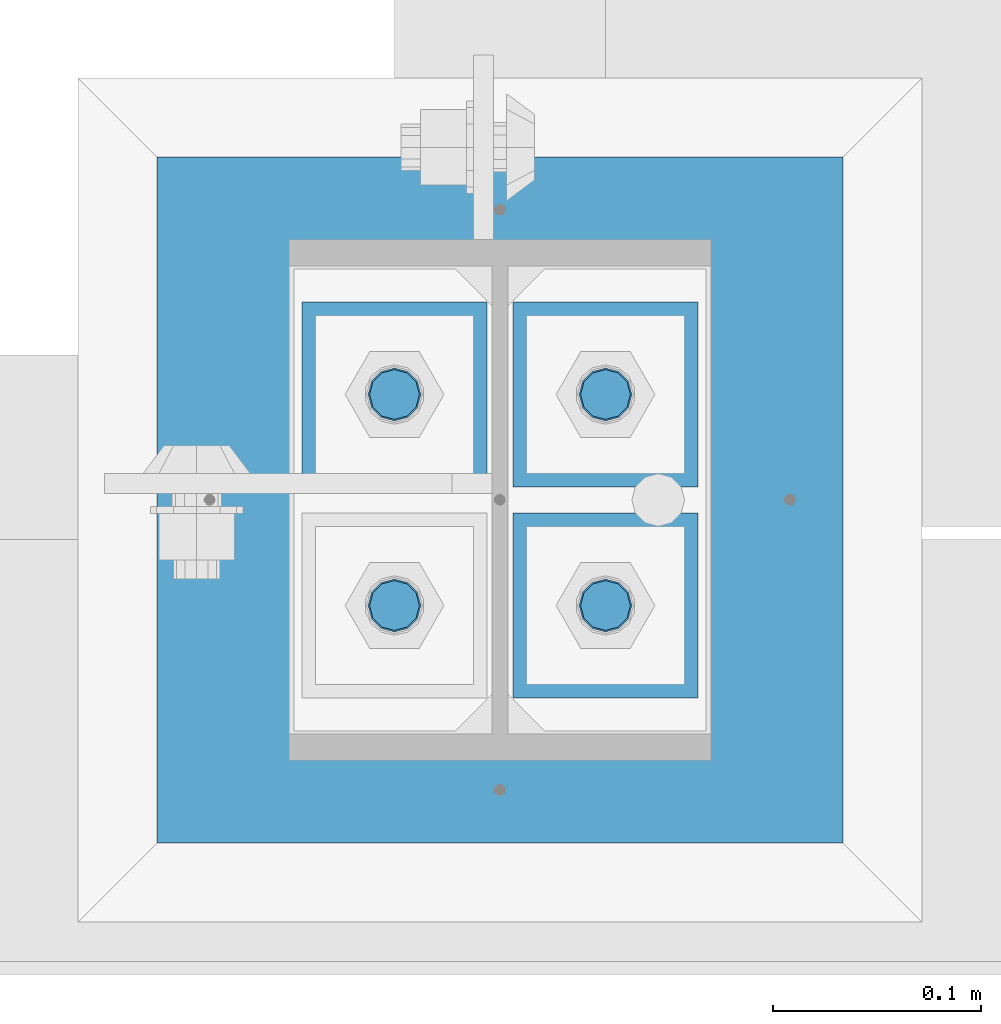
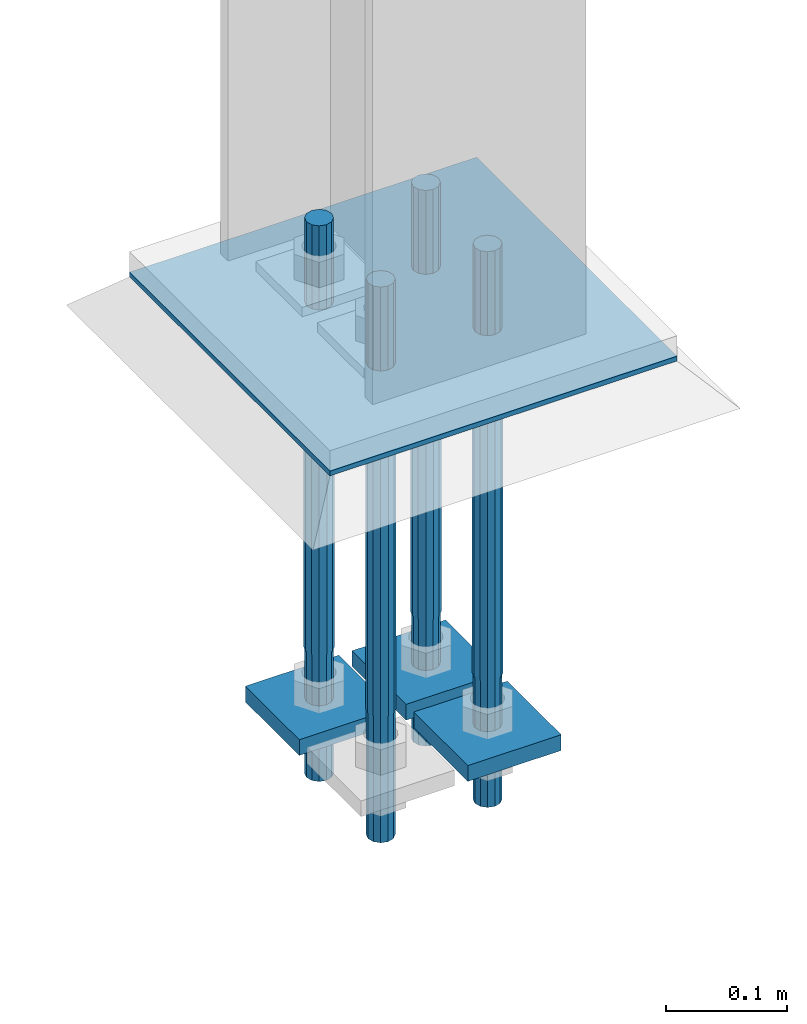
# One storey, part 2554 of 3843: 8 beams, 1 element without a shape of its own.
"""IFC2X3 building model written with IfcOpenShell, lengths in millimetres."""

from ifc_helpers import new_model, si_unit, frame, origin_with_axes, place, context, subcontext, project, spatial, faceted_brep, material, type_object, element, aggregate, save


model = new_model("IFC2X3")

# Units and contexts
model_context = context("Model", 3, precision=1e-05, world=origin_with_axes())
body_context = subcontext(model_context, "Body", "Model", "MODEL_VIEW")
ifc_project = project(units=[si_unit("LENGTHUNIT", "METRE", prefix="MILLI"), si_unit("AREAUNIT", "SQUARE_METRE"), si_unit("VOLUMEUNIT", "CUBIC_METRE"), si_unit("MASSUNIT", "GRAM", prefix="KILO"), si_unit("TIMEUNIT", "SECOND"), si_unit("PLANEANGLEUNIT", "RADIAN"), si_unit("SOLIDANGLEUNIT", "STERADIAN"), si_unit("THERMODYNAMICTEMPERATUREUNIT", "DEGREE_CELSIUS"), si_unit("LUMINOUSINTENSITYUNIT", "LUMEN")], contexts=[model_context])

# Site, building, storey
site_placement = place(None, origin_with_axes())
site = spatial("IfcSite", under=ifc_project, at=site_placement, CompositionType="ELEMENT")
building_placement = place(site_placement, origin_with_axes())
building = spatial("IfcBuilding", under=site, at=building_placement, Name="Undefined", CompositionType="ELEMENT")
storey_placement = place(building_placement, origin_with_axes())
storey = spatial("IfcBuildingStorey", under=building, at=storey_placement, Name="Undefined", CompositionType="ELEMENT", Elevation=0.0)

# Assembly, beams
assembly_placement = place(storey_placement, origin_with_axes())
assembly = element("IfcElementAssembly", 1, at=assembly_placement, inside=storey, Name="TEMPLATE", AssemblyPlace="NOTDEFINED", PredefinedType="RIGID_FRAME")
ifc_material_1 = material(Name="Undefined/F1554-GR.55")
beam_type_1 = type_object("IfcBeamType", PredefinedType="NOTDEFINED")
beam_1_placement = place(assembly_placement, frame((85598.0, 10985.5, 30022.8), z_axis=(0.0, -1.0, 0.0), x_axis=(0.0, 0.0, -1.0)))
beam_1 = element("IfcBeam", 2, at=beam_1_placement, type_object=beam_type_1, material=ifc_material_1, Name="ANCHOR_ROD", context=body_context, shape_type="Brep", body=[
    faceted_brep([(-127.0, -10.3923048454162, 6.0), (-127.0, -6.0, 10.3923048454126), (-127.0, 0.0, 12.0), (-127.0, 6.0, 10.3923048454126), (-127.0, 10.3923048454162, 6.0), (-127.0, 12.0, 0.0), (-127.0, 10.3923048454162, -6.0), (-127.0, 6.0, -10.3923048454126), (-127.0, 0.0, -12.0), (-127.0, -6.0, -10.3923048454126), (-127.0, -10.3923048454162, -6.0), (-127.0, -12.0, 0.0), (0.0, 12.0, 0.0), (0.0, 10.3923048454162, -6.0), (0.0, 6.0, -10.3923048454126), (0.0, 0.0, -12.0), (0.0, -6.0, -10.3923048454126), (0.0, -10.3923048454162, -6.0), (0.0, -12.0, 0.0), (0.0, -10.3923048454162, 6.0), (0.0, -6.0, 10.3923048454126), (0.0, 0.0, 12.0), (0.0, 6.0, 10.3923048454126), (0.0, 10.3923048454162, 6.0), (0.0, -10.9985226280696, 6.34999999999854), (0.0, -6.35000000000582, 10.9985226280623), (0.0, 0.0, 12.6999999999971), (0.0, 6.35000000000582, 10.9985226280623), (0.0, 10.9985226280696, 6.34999999999854), (0.0, 12.6999999999971, 0.0), (0.0, 10.9985226280696, -6.34999999999854), (0.0, 6.35000000000582, -10.9985226280623), (0.0, 0.0, -12.6999999999971), (0.0, -6.35000000000582, -10.9985226280623), (0.0, -10.9985226280696, -6.34999999999854), (0.0, -12.6999999999971, 0.0), (304.799999999999, -12.6999999999971, 0.0), (304.799999999999, -10.9985226280623, 6.35000000000036), (304.799999999999, -6.34999999999854, 10.9985226280623), (304.799999999999, 0.0, 12.7000000000007), (304.799999999999, 6.34999999999854, 10.9985226280623), (304.799999999999, 10.9985226280623, 6.35000000000036), (304.799999999999, 12.6999999999971, 0.0), (304.799999999999, 10.9985226280623, -6.35000000000036), (304.799999999999, 6.34999999999854, -10.9985226280623), (304.799999999999, 0.0, -12.7000000000007), (304.799999999999, -6.34999999999854, -10.9985226280623), (304.799999999999, -10.9985226280623, -6.35000000000036), (304.799999999999, -6.0, 10.3923048454126), (304.799999999999, 0.0, 12.0), (304.799999999999, 6.0, 10.3923048454126), (304.799999999999, 10.3923048454162, 6.0), (304.799999999999, 12.0, 0.0), (304.799999999999, 10.3923048454162, -6.0), (304.799999999999, 6.0, -10.3923048454126), (304.799999999999, 0.0, -12.0), (304.799999999999, -6.0, -10.3923048454126), (304.799999999999, -10.3923048454162, -6.0), (304.799999999999, -12.0, 0.0), (304.799999999999, -10.3923048454162, 6.0), (431.799999999999, -6.0, -10.3923048454126), (431.799999999999, 0.0, -12.0), (431.799999999999, 6.0, -10.3923048454126), (431.799999999999, 10.3923048454162, -6.0), (431.799999999999, 12.0, 0.0), (431.799999999999, 10.3923048454162, 6.0), (431.799999999999, 6.0, 10.3923048454126), (431.799999999999, 0.0, 12.0), (431.799999999999, -6.0, 10.3923048454126), (431.799999999999, -10.3923048454162, 6.0), (431.799999999999, -12.0, 0.0), (431.799999999999, -10.3923048454162, -6.0)], [[[0, 1, 2, 3, 4, 5, 6, 7, 8, 9, 10, 11]], [[6, 5, 12, 13]], [[7, 6, 13, 14]], [[8, 7, 14, 15]], [[9, 8, 15, 16]], [[10, 9, 16, 17]], [[11, 10, 17, 18]], [[0, 11, 18, 19]], [[1, 0, 19, 20]], [[2, 1, 20, 21]], [[3, 2, 21, 22]], [[4, 3, 22, 23]], [[5, 4, 23, 12]], [[24, 25, 26, 27, 28, 29, 30, 31, 32, 33, 34, 35], [22, 21, 20, 19, 18, 17, 16, 15, 14, 13, 12, 23]], [[24, 35, 36, 37]], [[25, 24, 37, 38]], [[26, 25, 38, 39]], [[27, 26, 39, 40]], [[28, 27, 40, 41]], [[29, 28, 41, 42]], [[30, 29, 42, 43]], [[31, 30, 43, 44]], [[32, 31, 44, 45]], [[33, 32, 45, 46]], [[34, 33, 46, 47]], [[35, 34, 47, 36]], [[46, 45, 44, 43, 42, 41, 40, 39, 38, 37, 36, 47], [48, 49, 50, 51, 52, 53, 54, 55, 56, 57, 58, 59]], [[60, 61, 62, 63, 64, 65, 66, 67, 68, 69, 70, 71]], [[68, 67, 49, 48]], [[69, 68, 48, 59]], [[70, 69, 59, 58]], [[71, 70, 58, 57]], [[60, 71, 57, 56]], [[61, 60, 56, 55]], [[62, 61, 55, 54]], [[63, 62, 54, 53]], [[64, 63, 53, 52]], [[65, 64, 52, 51]], [[66, 65, 51, 50]], [[67, 66, 50, 49]]]),
])
beam_2_placement = place(assembly_placement, frame((85699.6, 10985.5, 30022.8), z_axis=(0.0, 1.0, 0.0), x_axis=(0.0, 0.0, -1.0)))
beam_2 = element("IfcBeam", 3, at=beam_2_placement, type_object=beam_type_1, material=ifc_material_1, Name="ANCHOR_ROD", context=body_context, shape_type="Brep", body=[
    faceted_brep([(-127.0, -10.3923048454162, 6.0), (-127.0, -6.0, 10.3923048454126), (-127.0, 0.0, 12.0), (-127.0, 6.0, 10.3923048454126), (-127.0, 10.3923048454162, 6.0), (-127.0, 12.0, 0.0), (-127.0, 10.3923048454162, -6.0), (-127.0, 6.0, -10.3923048454126), (-127.0, 0.0, -12.0), (-127.0, -6.0, -10.3923048454126), (-127.0, -10.3923048454162, -6.0), (-127.0, -12.0, 0.0), (0.0, 12.0, 0.0), (0.0, 10.3923048454162, -6.0), (0.0, 6.0, -10.3923048454126), (0.0, 0.0, -12.0), (0.0, -6.0, -10.3923048454126), (0.0, -10.3923048454162, -6.0), (0.0, -12.0, 0.0), (0.0, -10.3923048454162, 6.0), (0.0, -6.0, 10.3923048454126), (0.0, 0.0, 12.0), (0.0, 6.0, 10.3923048454126), (0.0, 10.3923048454162, 6.0), (0.0, -10.9985226280696, 6.34999999999854), (0.0, -6.35000000000582, 10.9985226280623), (0.0, 0.0, 12.6999999999971), (0.0, 6.35000000000582, 10.9985226280623), (0.0, 10.9985226280696, 6.34999999999854), (0.0, 12.6999999999971, 0.0), (0.0, 10.9985226280696, -6.34999999999854), (0.0, 6.35000000000582, -10.9985226280623), (0.0, 0.0, -12.6999999999971), (0.0, -6.35000000000582, -10.9985226280623), (0.0, -10.9985226280696, -6.34999999999854), (0.0, -12.6999999999971, 0.0), (304.799999999999, -12.6999999999971, 0.0), (304.799999999999, -10.9985226280623, 6.35000000000036), (304.799999999999, -6.34999999999854, 10.9985226280623), (304.799999999999, 0.0, 12.7000000000007), (304.799999999999, 6.34999999999854, 10.9985226280623), (304.799999999999, 10.9985226280623, 6.35000000000036), (304.799999999999, 12.6999999999971, 0.0), (304.799999999999, 10.9985226280623, -6.35000000000036), (304.799999999999, 6.34999999999854, -10.9985226280623), (304.799999999999, 0.0, -12.7000000000007), (304.799999999999, -6.34999999999854, -10.9985226280623), (304.799999999999, -10.9985226280623, -6.35000000000036), (304.799999999999, -6.0, 10.3923048454126), (304.799999999999, 0.0, 12.0), (304.799999999999, 6.0, 10.3923048454126), (304.799999999999, 10.3923048454162, 6.0), (304.799999999999, 12.0, 0.0), (304.799999999999, 10.3923048454162, -6.0), (304.799999999999, 6.0, -10.3923048454126), (304.799999999999, 0.0, -12.0), (304.799999999999, -6.0, -10.3923048454126), (304.799999999999, -10.3923048454162, -6.0), (304.799999999999, -12.0, 0.0), (304.799999999999, -10.3923048454162, 6.0), (431.799999999999, -6.0, -10.3923048454126), (431.799999999999, 0.0, -12.0), (431.799999999999, 6.0, -10.3923048454126), (431.799999999999, 10.3923048454162, -6.0), (431.799999999999, 12.0, 0.0), (431.799999999999, 10.3923048454162, 6.0), (431.799999999999, 6.0, 10.3923048454126), (431.799999999999, 0.0, 12.0), (431.799999999999, -6.0, 10.3923048454126), (431.799999999999, -10.3923048454162, 6.0), (431.799999999999, -12.0, 0.0), (431.799999999999, -10.3923048454162, -6.0)], [[[0, 1, 2, 3, 4, 5, 6, 7, 8, 9, 10, 11]], [[6, 5, 12, 13]], [[7, 6, 13, 14]], [[8, 7, 14, 15]], [[9, 8, 15, 16]], [[10, 9, 16, 17]], [[11, 10, 17, 18]], [[0, 11, 18, 19]], [[1, 0, 19, 20]], [[2, 1, 20, 21]], [[3, 2, 21, 22]], [[4, 3, 22, 23]], [[5, 4, 23, 12]], [[24, 25, 26, 27, 28, 29, 30, 31, 32, 33, 34, 35], [22, 21, 20, 19, 18, 17, 16, 15, 14, 13, 12, 23]], [[24, 35, 36, 37]], [[25, 24, 37, 38]], [[26, 25, 38, 39]], [[27, 26, 39, 40]], [[28, 27, 40, 41]], [[29, 28, 41, 42]], [[30, 29, 42, 43]], [[31, 30, 43, 44]], [[32, 31, 44, 45]], [[33, 32, 45, 46]], [[34, 33, 46, 47]], [[35, 34, 47, 36]], [[46, 45, 44, 43, 42, 41, 40, 39, 38, 37, 36, 47], [48, 49, 50, 51, 52, 53, 54, 55, 56, 57, 58, 59]], [[60, 61, 62, 63, 64, 65, 66, 67, 68, 69, 70, 71]], [[68, 67, 49, 48]], [[69, 68, 48, 59]], [[70, 69, 59, 58]], [[71, 70, 58, 57]], [[60, 71, 57, 56]], [[61, 60, 56, 55]], [[62, 61, 55, 54]], [[63, 62, 54, 53]], [[64, 63, 53, 52]], [[65, 64, 52, 51]], [[66, 65, 51, 50]], [[67, 66, 50, 49]]]),
])
beam_3_placement = place(assembly_placement, frame((85598.0, 11087.1, 30022.8), z_axis=(0.0, -1.0, 0.0), x_axis=(0.0, 0.0, -1.0)))
beam_3 = element("IfcBeam", 4, at=beam_3_placement, type_object=beam_type_1, material=ifc_material_1, Name="ANCHOR_ROD", context=body_context, shape_type="Brep", body=[
    faceted_brep([(-127.0, -10.3923048454162, 6.0), (-127.0, -6.0, 10.3923048454126), (-127.0, 0.0, 12.0), (-127.0, 6.0, 10.3923048454126), (-127.0, 10.3923048454162, 6.0), (-127.0, 12.0, 0.0), (-127.0, 10.3923048454162, -6.0), (-127.0, 6.0, -10.3923048454126), (-127.0, 0.0, -12.0), (-127.0, -6.0, -10.3923048454126), (-127.0, -10.3923048454162, -6.0), (-127.0, -12.0, 0.0), (0.0, 12.0, 0.0), (0.0, 10.3923048454162, -6.0), (0.0, 6.0, -10.3923048454126), (0.0, 0.0, -12.0), (0.0, -6.0, -10.3923048454126), (0.0, -10.3923048454162, -6.0), (0.0, -12.0, 0.0), (0.0, -10.3923048454162, 6.0), (0.0, -6.0, 10.3923048454126), (0.0, 0.0, 12.0), (0.0, 6.0, 10.3923048454126), (0.0, 10.3923048454162, 6.0), (0.0, -10.9985226280696, 6.34999999999854), (0.0, -6.35000000000582, 10.9985226280623), (0.0, 0.0, 12.6999999999971), (0.0, 6.35000000000582, 10.9985226280623), (0.0, 10.9985226280696, 6.34999999999854), (0.0, 12.6999999999971, 0.0), (0.0, 10.9985226280696, -6.34999999999854), (0.0, 6.35000000000582, -10.9985226280623), (0.0, 0.0, -12.6999999999971), (0.0, -6.35000000000582, -10.9985226280623), (0.0, -10.9985226280696, -6.34999999999854), (0.0, -12.6999999999971, 0.0), (304.799999999999, -12.6999999999971, 0.0), (304.799999999999, -10.9985226280623, 6.35000000000036), (304.799999999999, -6.34999999999854, 10.9985226280623), (304.799999999999, 0.0, 12.7000000000007), (304.799999999999, 6.34999999999854, 10.9985226280623), (304.799999999999, 10.9985226280623, 6.35000000000036), (304.799999999999, 12.6999999999971, 0.0), (304.799999999999, 10.9985226280623, -6.35000000000036), (304.799999999999, 6.34999999999854, -10.9985226280623), (304.799999999999, 0.0, -12.7000000000007), (304.799999999999, -6.34999999999854, -10.9985226280623), (304.799999999999, -10.9985226280623, -6.35000000000036), (304.799999999999, -6.0, 10.3923048454126), (304.799999999999, 0.0, 12.0), (304.799999999999, 6.0, 10.3923048454126), (304.799999999999, 10.3923048454162, 6.0), (304.799999999999, 12.0, 0.0), (304.799999999999, 10.3923048454162, -6.0), (304.799999999999, 6.0, -10.3923048454126), (304.799999999999, 0.0, -12.0), (304.799999999999, -6.0, -10.3923048454126), (304.799999999999, -10.3923048454162, -6.0), (304.799999999999, -12.0, 0.0), (304.799999999999, -10.3923048454162, 6.0), (431.799999999999, -6.0, -10.3923048454126), (431.799999999999, 0.0, -12.0), (431.799999999999, 6.0, -10.3923048454126), (431.799999999999, 10.3923048454162, -6.0), (431.799999999999, 12.0, 0.0), (431.799999999999, 10.3923048454162, 6.0), (431.799999999999, 6.0, 10.3923048454126), (431.799999999999, 0.0, 12.0), (431.799999999999, -6.0, 10.3923048454126), (431.799999999999, -10.3923048454162, 6.0), (431.799999999999, -12.0, 0.0), (431.799999999999, -10.3923048454162, -6.0)], [[[0, 1, 2, 3, 4, 5, 6, 7, 8, 9, 10, 11]], [[6, 5, 12, 13]], [[7, 6, 13, 14]], [[8, 7, 14, 15]], [[9, 8, 15, 16]], [[10, 9, 16, 17]], [[11, 10, 17, 18]], [[0, 11, 18, 19]], [[1, 0, 19, 20]], [[2, 1, 20, 21]], [[3, 2, 21, 22]], [[4, 3, 22, 23]], [[5, 4, 23, 12]], [[24, 25, 26, 27, 28, 29, 30, 31, 32, 33, 34, 35], [22, 21, 20, 19, 18, 17, 16, 15, 14, 13, 12, 23]], [[24, 35, 36, 37]], [[25, 24, 37, 38]], [[26, 25, 38, 39]], [[27, 26, 39, 40]], [[28, 27, 40, 41]], [[29, 28, 41, 42]], [[30, 29, 42, 43]], [[31, 30, 43, 44]], [[32, 31, 44, 45]], [[33, 32, 45, 46]], [[34, 33, 46, 47]], [[35, 34, 47, 36]], [[46, 45, 44, 43, 42, 41, 40, 39, 38, 37, 36, 47], [48, 49, 50, 51, 52, 53, 54, 55, 56, 57, 58, 59]], [[60, 61, 62, 63, 64, 65, 66, 67, 68, 69, 70, 71]], [[68, 67, 49, 48]], [[69, 68, 48, 59]], [[70, 69, 59, 58]], [[71, 70, 58, 57]], [[60, 71, 57, 56]], [[61, 60, 56, 55]], [[62, 61, 55, 54]], [[63, 62, 54, 53]], [[64, 63, 53, 52]], [[65, 64, 52, 51]], [[66, 65, 51, 50]], [[67, 66, 50, 49]]]),
])
beam_4_placement = place(assembly_placement, frame((85699.6, 11087.1, 30022.8), z_axis=(0.0, 1.0, 0.0), x_axis=(0.0, 0.0, -1.0)))
beam_4 = element("IfcBeam", 5, at=beam_4_placement, type_object=beam_type_1, material=ifc_material_1, Name="ANCHOR_ROD", context=body_context, shape_type="Brep", body=[
    faceted_brep([(-127.0, -10.3923048454162, 6.0), (-127.0, -6.0, 10.3923048454126), (-127.0, 0.0, 12.0), (-127.0, 6.0, 10.3923048454126), (-127.0, 10.3923048454162, 6.0), (-127.0, 12.0, 0.0), (-127.0, 10.3923048454162, -6.0), (-127.0, 6.0, -10.3923048454126), (-127.0, 0.0, -12.0), (-127.0, -6.0, -10.3923048454126), (-127.0, -10.3923048454162, -6.0), (-127.0, -12.0, 0.0), (0.0, 12.0, 0.0), (0.0, 10.3923048454162, -6.0), (0.0, 6.0, -10.3923048454126), (0.0, 0.0, -12.0), (0.0, -6.0, -10.3923048454126), (0.0, -10.3923048454162, -6.0), (0.0, -12.0, 0.0), (0.0, -10.3923048454162, 6.0), (0.0, -6.0, 10.3923048454126), (0.0, 0.0, 12.0), (0.0, 6.0, 10.3923048454126), (0.0, 10.3923048454162, 6.0), (0.0, -10.9985226280696, 6.34999999999854), (0.0, -6.35000000000582, 10.9985226280623), (0.0, 0.0, 12.6999999999971), (0.0, 6.35000000000582, 10.9985226280623), (0.0, 10.9985226280696, 6.34999999999854), (0.0, 12.6999999999971, 0.0), (0.0, 10.9985226280696, -6.34999999999854), (0.0, 6.35000000000582, -10.9985226280623), (0.0, 0.0, -12.6999999999971), (0.0, -6.35000000000582, -10.9985226280623), (0.0, -10.9985226280696, -6.34999999999854), (0.0, -12.6999999999971, 0.0), (304.799999999999, -12.6999999999971, 0.0), (304.799999999999, -10.9985226280623, 6.35000000000036), (304.799999999999, -6.34999999999854, 10.9985226280623), (304.799999999999, 0.0, 12.7000000000007), (304.799999999999, 6.34999999999854, 10.9985226280623), (304.799999999999, 10.9985226280623, 6.35000000000036), (304.799999999999, 12.6999999999971, 0.0), (304.799999999999, 10.9985226280623, -6.35000000000036), (304.799999999999, 6.34999999999854, -10.9985226280623), (304.799999999999, 0.0, -12.7000000000007), (304.799999999999, -6.34999999999854, -10.9985226280623), (304.799999999999, -10.9985226280623, -6.35000000000036), (304.799999999999, -6.0, 10.3923048454126), (304.799999999999, 0.0, 12.0), (304.799999999999, 6.0, 10.3923048454126), (304.799999999999, 10.3923048454162, 6.0), (304.799999999999, 12.0, 0.0), (304.799999999999, 10.3923048454162, -6.0), (304.799999999999, 6.0, -10.3923048454126), (304.799999999999, 0.0, -12.0), (304.799999999999, -6.0, -10.3923048454126), (304.799999999999, -10.3923048454162, -6.0), (304.799999999999, -12.0, 0.0), (304.799999999999, -10.3923048454162, 6.0), (431.799999999999, -6.0, -10.3923048454126), (431.799999999999, 0.0, -12.0), (431.799999999999, 6.0, -10.3923048454126), (431.799999999999, 10.3923048454162, -6.0), (431.799999999999, 12.0, 0.0), (431.799999999999, 10.3923048454162, 6.0), (431.799999999999, 6.0, 10.3923048454126), (431.799999999999, 0.0, 12.0), (431.799999999999, -6.0, 10.3923048454126), (431.799999999999, -10.3923048454162, 6.0), (431.799999999999, -12.0, 0.0), (431.799999999999, -10.3923048454162, -6.0)], [[[0, 1, 2, 3, 4, 5, 6, 7, 8, 9, 10, 11]], [[6, 5, 12, 13]], [[7, 6, 13, 14]], [[8, 7, 14, 15]], [[9, 8, 15, 16]], [[10, 9, 16, 17]], [[11, 10, 17, 18]], [[0, 11, 18, 19]], [[1, 0, 19, 20]], [[2, 1, 20, 21]], [[3, 2, 21, 22]], [[4, 3, 22, 23]], [[5, 4, 23, 12]], [[24, 25, 26, 27, 28, 29, 30, 31, 32, 33, 34, 35], [22, 21, 20, 19, 18, 17, 16, 15, 14, 13, 12, 23]], [[24, 35, 36, 37]], [[25, 24, 37, 38]], [[26, 25, 38, 39]], [[27, 26, 39, 40]], [[28, 27, 40, 41]], [[29, 28, 41, 42]], [[30, 29, 42, 43]], [[31, 30, 43, 44]], [[32, 31, 44, 45]], [[33, 32, 45, 46]], [[34, 33, 46, 47]], [[35, 34, 47, 36]], [[46, 45, 44, 43, 42, 41, 40, 39, 38, 37, 36, 47], [48, 49, 50, 51, 52, 53, 54, 55, 56, 57, 58, 59]], [[60, 61, 62, 63, 64, 65, 66, 67, 68, 69, 70, 71]], [[68, 67, 49, 48]], [[69, 68, 48, 59]], [[70, 69, 59, 58]], [[71, 70, 58, 57]], [[60, 71, 57, 56]], [[61, 60, 56, 55]], [[62, 61, 55, 54]], [[63, 62, 54, 53]], [[64, 63, 53, 52]], [[65, 64, 52, 51]], [[66, 65, 51, 50]], [[67, 66, 50, 49]]]),
])
ifc_material_2 = material(Name="STEEL/A572-50")
beam_type_2 = type_object("IfcBeamType", PredefinedType="NOTDEFINED")
beam_5_placement = place(assembly_placement, frame((85699.6, 10941.05, 29659.2625), z_axis=(1.0, 0.0, 0.0), x_axis=(0.0, 1.0, 0.0)))
beam_5 = element("IfcBeam", 6, at=beam_5_placement, type_object=beam_type_2, material=ifc_material_2, context=body_context, shape_type="Brep", body=[
    faceted_brep([(0.0, 7.9375, -44.4499999999971), (0.0, 7.9375, 44.4499999999971), (88.8999999999942, 7.9375, 44.4499999999971), (88.8999999999942, 7.9375, -44.4499999999971), (0.0, -7.9375, 44.4499999999971), (88.8999999999942, -7.9375, 44.4499999999971), (0.0, -7.9375, -44.4499999999971), (88.8999999999942, -7.9375, -44.4499999999971)], [[[0, 1, 2, 3]], [[1, 4, 5, 2]], [[4, 6, 7, 5]], [[6, 0, 3, 7]], [[5, 7, 3, 2]], [[6, 4, 1, 0]]]),
])
beam_6_placement = place(assembly_placement, frame((85598.0, 11042.65, 29659.2625), z_axis=(1.0, 0.0, 0.0), x_axis=(0.0, 1.0, 0.0)))
beam_6 = element("IfcBeam", 7, at=beam_6_placement, type_object=beam_type_2, material=ifc_material_2, context=body_context, shape_type="Brep", body=[
    faceted_brep([(0.0, 7.9375, -44.4499999999971), (0.0, 7.9375, 44.4499999999971), (88.8999999999942, 7.9375, 44.4499999999971), (88.8999999999942, 7.9375, -44.4499999999971), (0.0, -7.9375, 44.4499999999971), (88.8999999999942, -7.9375, 44.4499999999971), (0.0, -7.9375, -44.4499999999971), (88.8999999999942, -7.9375, -44.4499999999971)], [[[0, 1, 2, 3]], [[1, 4, 5, 2]], [[4, 6, 7, 5]], [[6, 0, 3, 7]], [[5, 7, 3, 2]], [[6, 4, 1, 0]]]),
])
beam_7_placement = place(assembly_placement, frame((85699.6, 11042.65, 29659.2625), z_axis=(1.0, 0.0, 0.0), x_axis=(0.0, 1.0, 0.0)))
beam_7 = element("IfcBeam", 8, at=beam_7_placement, type_object=beam_type_2, material=ifc_material_2, context=body_context, shape_type="Brep", body=[
    faceted_brep([(0.0, 7.9375, -44.4499999999971), (0.0, 7.9375, 44.4499999999971), (88.8999999999942, 7.9375, 44.4499999999971), (88.8999999999942, 7.9375, -44.4499999999971), (0.0, -7.9375, 44.4499999999971), (88.8999999999942, -7.9375, 44.4499999999971), (0.0, -7.9375, -44.4499999999971), (88.8999999999942, -7.9375, -44.4499999999971)], [[[0, 1, 2, 3]], [[1, 4, 5, 2]], [[4, 6, 7, 5]], [[6, 0, 3, 7]], [[5, 7, 3, 2]], [[6, 4, 1, 0]]]),
])
beam_type_3 = type_object("IfcBeamType", PredefinedType="NOTDEFINED")
beam_8_placement = place(assembly_placement, frame((85648.8, 10871.2004997253, 30063.2815), z_axis=(-1.0, 0.0, 0.0), x_axis=(0.0, 1.0, 0.0)))
beam_8 = element("IfcBeam", 9, at=beam_8_placement, type_object=beam_type_3, material=ifc_material_2, Name="TEMPLATE", context=body_context, shape_type="Brep", body=[
    faceted_brep([(0.0, 2.38149999999951, -165.100000000006), (0.0, 2.38149999999951, 165.100000000006), (330.199996948242, 2.38149999999951, 165.100000000006), (330.199996948242, 2.38149999999951, -165.100000000006), (0.0, -2.38149999999951, 165.100000000006), (330.199996948242, -2.38149999999951, 165.100000000006), (0.0, -2.38149999999951, -165.100000000006), (330.199996948242, -2.38149999999951, -165.100000000006)], [[[0, 1, 2, 3]], [[1, 4, 5, 2]], [[4, 6, 7, 5]], [[6, 0, 3, 7]], [[5, 7, 3, 2]], [[6, 4, 1, 0]]]),
])
aggregate(assembly, [beam_1, beam_5, beam_2, beam_6, beam_3, beam_7, beam_4, beam_8])

save(model, "model.ifc")
